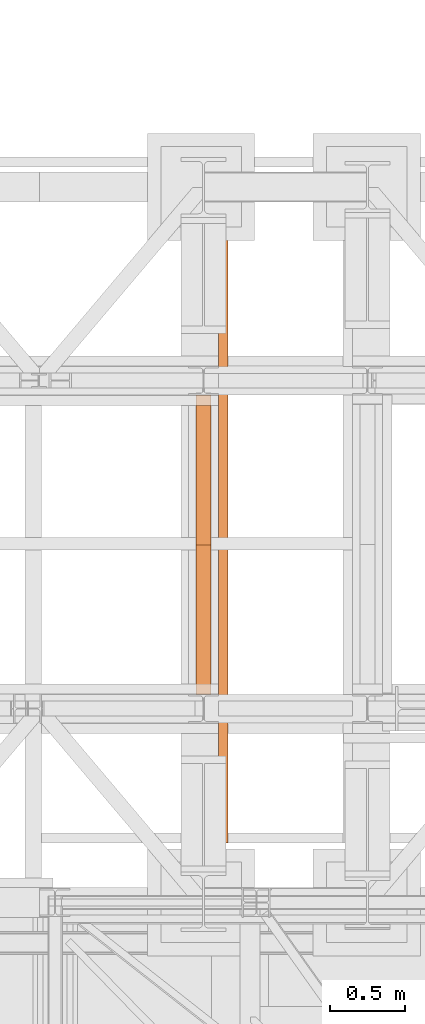
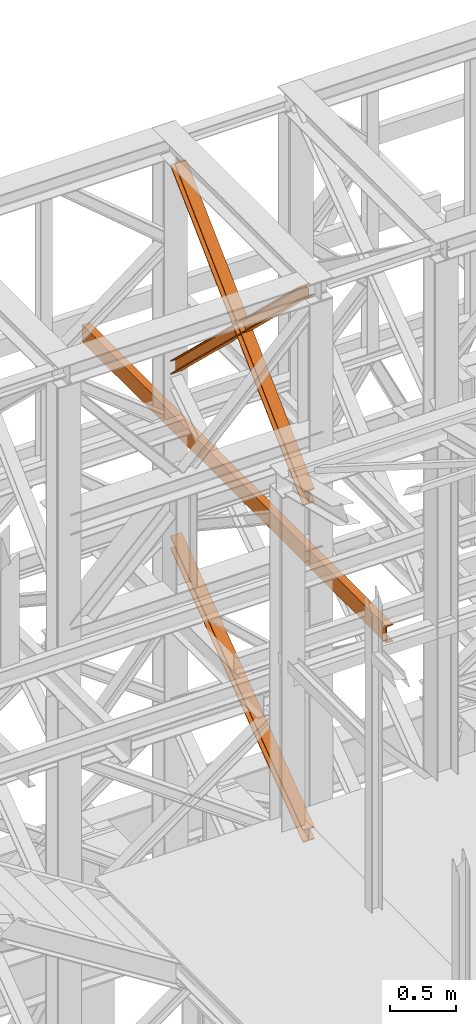
# One storey, part 123 of 208: 4 proxies.
"""IFC2X3 building model written with IfcOpenShell, lengths in millimetres."""

from ifc_helpers import new_model, entity, si_unit, converted_unit, frame, origin, origin_with_axes, place, context, subcontext, project, spatial, faceted_brep, element, save


model = new_model("IFC2X3")

# Units and contexts
model_context = context("Model", 3, precision=1e-05, world=origin())
plan_context = context("Plan", 3, precision=1e-05, world=origin())
body_context = subcontext(model_context, "Body", "Model", "MODEL_VIEW")
ifc_project = project(units=[si_unit("LENGTHUNIT", "METRE", prefix="MILLI"), converted_unit("PLANEANGLEUNIT", "DEGREE", entity("IfcPlaneAngleMeasure", 0.0174532925199433), si_unit("PLANEANGLEUNIT", "RADIAN"), dimensions=[0, 0, 0, 0, 0, 0, 0]), si_unit("AREAUNIT", "SQUARE_METRE"), si_unit("VOLUMEUNIT", "CUBIC_METRE")], contexts=[model_context, plan_context])

# Building, storey
building_placement = place(None, origin())
building = spatial("IfcBuilding", under=ifc_project, at=building_placement, CompositionType="COMPLEX")
storey_placement = place(building_placement, origin_with_axes())
storey = spatial("IfcBuildingStorey", under=building, at=storey_placement, Name="Geschoss", CompositionType="ELEMENT")

# Proxies
proxy_1_placement = place(storey_placement, frame((2142.895647595429, -15867.5743840594, 7147.394064575148), z_axis=(0.0, 0.0, 1.0), x_axis=(1.0, 0.0, 0.0)))
element("IfcBuildingElementProxy", 1, at=proxy_1_placement, inside=storey, context=body_context, shape_type="Brep", body=[
    faceted_brep([(100.0229386519513, 2010.009987483025, 1501.524522111415), (100.185572907496, 0.01000000000021828, 0.02100513656296243), (100.1844946360361, 0.01000000000021828, 9.82075546136366), (100.0218603804915, 2010.009987483025, 1511.324272436212), (0.02293925751655479, 2010.009987483025, 1501.513516974852), (0.185573513059353, 0.01000000000021828, 0.01000000000021828), (100.185572907496, 0.01000000000021828, 0.02100513656296243), (100.0229386519513, 2010.009987483025, 1501.524522111415), (0.02186098605488951, 2010.009987483025, 1511.313267299649), (0.1844952415995067, 0.01000000000021828, 9.809750324800916), (0.185573513059353, 0.01000000000021828, 0.01000000000021828), (0.02293925751655479, 2010.009987483025, 1501.513516974852), (47.52186069841264, 2010.009987483025, 1511.318494739518), (47.68449495395544, 0.01000000000021828, 9.814977764666764), (0.1844952415995067, 0.01000000000021828, 9.809750324800916), (0.02186098605488951, 2010.009987483025, 1511.313267299649), (47.51107798381418, 2010.009987483025, 1609.315997987507), (47.67371223936061, 0.01000000000021828, 107.8124810126556), (47.68449495395544, 0.01000000000021828, 9.814977764666764), (47.52186069841264, 2010.009987483025, 1511.318494739518), (0.01107827146006457, 2010.009987483025, 1609.310770547641), (0.1737125270028628, 0.01000000000021828, 107.8072535727861), (47.67371223936061, 0.01000000000021828, 107.8124810126556), (47.51107798381418, 2010.009987483025, 1609.315997987507), (0.01000000000021828, 2010.009987483025, 1619.110520872438), (0.1726342555448355, 0.01000000000021828, 117.6070038975868), (0.1737125270028628, 0.01000000000021828, 107.8072535727861), (0.01107827146006457, 2010.009987483025, 1609.310770547641), (100.009999394435, 2010.009987483025, 1619.121526009001), (100.1726336499778, 0.01000000000021828, 117.6180090341495), (0.1726342555448355, 0.01000000000021828, 117.6070038975868), (0.01000000000021828, 2010.009987483025, 1619.110520872438), (100.0110776658949, 2010.009987483025, 1609.321775684197), (100.1737119214376, 0.01000000000021828, 107.8182587093452), (100.1726336499778, 0.01000000000021828, 117.6180090341495), (100.009999394435, 2010.009987483025, 1619.121526009001), (52.5110779535371, 2010.009987483025, 1609.316548244331), (52.67371220908353, 0.01000000000021828, 107.8130312694793), (100.1737119214376, 0.01000000000021828, 107.8182587093452), (100.0110776658949, 2010.009987483025, 1609.321775684197), (52.52186066813374, 2010.009987483025, 1511.319044996339), (52.68449492368018, 0.01000000000021828, 9.815528021497812), (52.67371220908353, 0.01000000000021828, 107.8130312694793), (52.5110779535371, 2010.009987483025, 1609.316548244331), (100.0218603804915, 2010.009987483025, 1511.324272436212), (100.1844946360361, 0.01000000000021828, 9.82075546136366), (52.68449492368018, 0.01000000000021828, 9.815528021497812), (52.52186066813374, 2010.009987483025, 1511.319044996339), (100.185572907496, 0.01000000000021828, 0.02100513656296243), (0.185573513059353, 0.01000000000021828, 0.01000000000021828), (0.1844952415995067, 0.01000000000021828, 9.809750324800916), (47.68449495395544, 0.01000000000021828, 9.814977764666764), (47.67371223936061, 0.01000000000021828, 107.8124810126556), (0.1737125270028628, 0.01000000000021828, 107.8072535727861), (0.1726342555448355, 0.01000000000021828, 117.6070038975868), (100.1726336499778, 0.01000000000021828, 117.6180090341495), (100.1737119214376, 0.01000000000021828, 107.8182587093452), (52.67371220908353, 0.01000000000021828, 107.8130312694793), (52.68449492368018, 0.01000000000021828, 9.815528021497812), (100.1844946360361, 0.01000000000021828, 9.82075546136366), (100.0218603804915, 2010.009987483025, 1511.324272436212), (52.52186066813374, 2010.009987483025, 1511.319044996339), (52.5110779535371, 2010.009987483025, 1609.316548244331), (100.0110776658949, 2010.009987483025, 1609.321775684197), (100.009999394435, 2010.009987483025, 1619.121526009001), (0.01000000000021828, 2010.009987483025, 1619.110520872438), (0.01107827146006457, 2010.009987483025, 1609.310770547641), (47.51107798381418, 2010.009987483025, 1609.315997987507), (47.52186069841264, 2010.009987483025, 1511.318494739518), (0.02186098605488951, 2010.009987483025, 1511.313267299649), (0.02293925751655479, 2010.009987483025, 1501.513516974852), (100.0229386519513, 2010.009987483025, 1501.524522111415)], [[[0, 1, 2, 3]], [[4, 5, 6, 7]], [[8, 9, 10, 11]], [[12, 13, 14, 15]], [[16, 17, 18, 19]], [[20, 21, 22, 23]], [[24, 25, 26, 27]], [[28, 29, 30, 31]], [[32, 33, 34, 35]], [[36, 37, 38, 39]], [[40, 41, 42, 43]], [[44, 45, 46, 47]], [[48, 49, 50, 51, 52, 53, 54, 55, 56, 57, 58, 59]], [[60, 61, 62, 63, 64, 65, 66, 67, 68, 69, 70, 71]]], orient=[[False], [False], [False], [False], [False], [False], [False], [False], [False], [False], [False], [False], [False], [False]]),
])
proxy_2_placement = place(storey_placement, frame((2142.709266073973, -15867.57439014891, 10257.71351554296), z_axis=(0.0, 0.0, 1.0), x_axis=(1.0, 0.0, 0.0)))
element("IfcBuildingElementProxy", 2, at=proxy_2_placement, inside=storey, context=body_context, shape_type="Brep", body=[
    faceted_brep([(100.0212045496901, 2010.009993572538, 119.6472293306997), (100.1463438185765, 56.72628223557149, 1992.286543150845), (100.1466350609662, 68.07077152448983, 1992.286543150845), (100.0222231921616, 2010.009993572536, 130.5233411127829), (100.0222231921616, 2010.009993572536, 130.5233411127829), (100.1466350609662, 68.07077152448983, 1992.286543150845), (0.1466348943758931, 68.08252523311057, 1992.286543150842), (0.02222377857833635, 2010.009993572536, 130.5346095510231), (0.02222377857833635, 2010.009993572536, 130.5346095510231), (0.1466348943758931, 68.08252523311057, 1992.286543150842), (0.1463436519825336, 56.73803594420861, 1992.286543150842), (0.02120513611225761, 2010.009993572536, 119.6584977689327), (0.02120513611225761, 2010.009993572536, 119.6584977689327), (0.1463436519825336, 56.73803594420861, 1992.286543150842), (47.64634373111403, 56.73245293260334, 1992.286543150845), (47.52120485756132, 2010.009993572536, 119.6531452607651), (47.52120485756132, 2010.009993572536, 119.6531452607651), (47.64634373111403, 56.73245293260334, 1992.286543150845), (47.64488761591929, 0.01000608951108006, 1992.286543150845), (47.63979748861675, 0.01000608951108006, 1937.905972056111), (47.51101837541864, 2010.009993572536, 10.89202766673589), (47.51101837541864, 2010.009993572536, 10.89202766673589), (47.63979748861675, 0.01000608951108006, 1937.905972056111), (0.1397977671695116, 0.01000608951108006, 1937.911324564264), (0.011018653971405, 2010.009993572536, 10.89738017488162), (0.011018653971405, 2010.009993572536, 10.89738017488162), (0.1397977671695116, 0.01000608951108006, 1937.911324564264), (0.138779739916572, 0.01000608951108006, 1927.035210352397), (0.01000000000021828, 2010.009993572536, 0.02126843821861257), (0.01000000000021828, 2010.009993572536, 0.02126843821861257), (0.138779739916572, 0.01000608951108006, 1927.035210352397), (100.1387791534962, 0.01000608951108006, 1927.023941914182), (100.0099994135762, 2010.009993572536, 0.01000000000021828), (100.0099994135762, 2010.009993572536, 0.01000000000021828), (100.1387791534962, 0.01000608951108006, 1927.023941914182), (100.1397971807455, 0.01000608951108006, 1937.900056126053), (100.0110180675511, 2010.009993572536, 10.88611173667414), (100.0110180675511, 2010.009993572536, 10.88611173667414), (100.1397971807455, 0.01000608951108006, 1937.900056126053), (52.63979745929828, 0.01000608951108006, 1937.905408634202), (52.51101834609835, 2010.009993572536, 10.89146424482351), (52.51101834609835, 2010.009993572536, 10.89146424482351), (52.63979745929828, 0.01000608951108006, 1937.905408634202), (52.64488763917871, 0.01000000000021828, 1992.286543150845), (52.64634373944318, 56.73186524717494, 1992.286543150845), (52.52120482823921, 2010.009993572536, 119.65258183886), (52.52120482823921, 2010.009993572536, 119.65258183886), (52.64634373944318, 56.73186524717494, 1992.286543150845), (100.1463438185765, 56.72628223557149, 1992.286543150845), (100.0212045496901, 2010.009993572538, 119.6472293306997), (100.1463438185765, 56.72628223557149, 1992.286543150845), (52.64634373944318, 56.73186524717494, 1992.286543150845), (52.64488763917871, 0.01000000000021828, 1992.286543150845), (47.64488761591929, 0.01000608951108006, 1992.286543150845), (47.64634373111403, 56.73245293260334, 1992.286543150845), (0.1463436519825336, 56.73803594420861, 1992.286543150842), (0.1466348943758931, 68.08252523311057, 1992.286543150842), (100.1466350609662, 68.07077152448983, 1992.286543150845), (47.64488761591929, 0.01000608951108006, 1992.286543150845), (52.64488763917871, 0.01000000000021828, 1992.286543150845), (52.63979745929828, 0.01000608951108006, 1937.905408634202), (100.1397971807455, 0.01000608951108006, 1937.900056126053), (100.1387791534962, 0.01000608951108006, 1927.023941914182), (0.138779739916572, 0.01000608951108006, 1927.035210352397), (0.1397977671695116, 0.01000608951108006, 1937.911324564264), (47.63979748861675, 0.01000608951108006, 1937.905972056111), (100.0222231921616, 2010.009993572536, 130.5233411127829), (0.02222377857833635, 2010.009993572536, 130.5346095510231), (0.02120513611225761, 2010.009993572536, 119.6584977689327), (47.52120485756132, 2010.009993572536, 119.6531452607651), (47.51101837541864, 2010.009993572536, 10.89202766673589), (0.011018653971405, 2010.009993572536, 10.89738017488162), (0.01000000000021828, 2010.009993572536, 0.02126843821861257), (100.0099994135762, 2010.009993572536, 0.01000000000021828), (100.0110180675511, 2010.009993572536, 10.88611173667414), (52.51101834609835, 2010.009993572536, 10.89146424482351), (52.52120482823921, 2010.009993572536, 119.65258183886), (100.0212045496901, 2010.009993572538, 119.6472293306997)], [[[0, 1, 2, 3]], [[4, 5, 6, 7]], [[8, 9, 10, 11]], [[12, 13, 14, 15]], [[16, 17, 18, 19, 20]], [[21, 22, 23, 24]], [[25, 26, 27, 28]], [[29, 30, 31, 32]], [[33, 34, 35, 36]], [[37, 38, 39, 40]], [[41, 42, 43, 44, 45]], [[46, 47, 48, 49]], [[50, 51, 52, 53, 54, 55, 56, 57]], [[58, 59, 60, 61, 62, 63, 64, 65]], [[66, 67, 68, 69, 70, 71, 72, 73, 74, 75, 76, 77]]], orient=[[False], [False], [False], [False], [False], [False], [False], [False], [False], [False], [False], [False], [False], [False], [False]]),
])
proxy_3_placement = place(storey_placement, frame((2142.729037453721, -15867.5743840594, 10261.20680675583), z_axis=(0.0, 0.0, 1.0), x_axis=(1.0, 0.0, 0.0)))
element("IfcBuildingElementProxy", 3, at=proxy_3_placement, inside=storey, context=body_context, shape_type="Brep", body=[
    faceted_brep([(100.0219376352106, 0.01000000000021828, 130.5376928144524), (100.1248673996142, 1937.888230286315, 1988.793251937981), (100.1244756427459, 1949.231612164787, 1988.793251937985), (100.0209427866557, 0.01000000000021828, 119.6603850577285), (0.02193825012000161, 0.01000000000021828, 130.5496157990219), (0.1248673541031167, 1937.875796424816, 1988.793251937981), (100.1248673996142, 1937.888230286315, 1988.793251937981), (100.0219376352106, 0.01000000000021828, 130.5376928144524), (0.02094340156691033, 0.01000000000021828, 119.6723080422798), (0.1244755972311396, 1949.21917830328, 1988.793251937981), (0.1248673541031167, 1937.875796424816, 1988.793251937981), (0.02193825012000161, 0.01000000000021828, 130.5496157990219), (47.52094310948451, 0.01000000000021828, 119.6666446246109), (47.62447561884983, 1949.225084387492, 1988.793251937981), (0.1244755972311396, 1949.21917830328, 1988.793251937981), (0.02094340156691033, 0.01000000000021828, 119.6723080422798), (47.51099456772136, 0.01000000000021828, 10.89356727918312), (47.61776178021319, 2010.009987483025, 1938.307550640491), (47.62237652174554, 2010.009987483025, 1988.793251937981), (47.62447561884983, 1949.225084387492, 1988.793251937981), (47.52094310948451, 0.01000000000021828, 119.6666446246109), (0.01099485980739701, 0.01000000000021828, 10.899230696823), (0.1177620722974098, 2010.009987483025, 1938.313214058149), (47.61776178021319, 2010.009987483025, 1938.307550640491), (47.51099456772136, 0.01000000000021828, 10.89356727918312), (0.01000000000021828, 0.01000000000021828, 0.02192298452973773), (0.1167678252622864, 2010.009987483025, 1927.43590392548), (0.1177620722974098, 2010.009987483025, 1938.313214058149), (0.01099485980739701, 0.01000000000021828, 10.899230696823), (100.0099993850836, 0.01000000000021828, 0.01000000000021828), (100.1167672103493, 2010.009987483025, 1927.42398094095), (0.1167678252622864, 2010.009987483025, 1927.43590392548), (0.01000000000021828, 0.01000000000021828, 0.02192298452973773), (100.0109942448944, 0.01000000000021828, 10.88730771230075), (100.117761457379, 2010.009987483025, 1938.301291073616), (100.1167672103493, 2010.009987483025, 1927.42398094095), (100.0099993850836, 0.01000000000021828, 0.01000000000021828), (52.51099453697134, 0.01000000000021828, 10.89297112994063), (52.61776174946681, 2010.009987483025, 1938.306954491263), (100.117761457379, 2010.009987483025, 1938.301291073616), (100.0109942448944, 0.01000000000021828, 10.88730771230075), (52.52094307873631, 0.01000000000021828, 119.6660484753793), (52.62447562112538, 1949.225706080566, 1988.793251937981), (52.62237654549062, 2010.009987483025, 1988.793251937981), (52.61776174946681, 2010.009987483025, 1938.306954491263), (52.51099453697134, 0.01000000000021828, 10.89297112994063), (100.0209427866557, 0.01000000000021828, 119.6603850577285), (100.1244756427459, 1949.231612164787, 1988.793251937985), (52.62447562112538, 1949.225706080566, 1988.793251937981), (52.52094307873631, 0.01000000000021828, 119.6660484753793), (100.1248673996142, 1937.888230286315, 1988.793251937981), (0.1248673541031167, 1937.875796424816, 1988.793251937981), (0.1244755972311396, 1949.21917830328, 1988.793251937981), (47.62447561884983, 1949.225084387492, 1988.793251937981), (47.62237652174554, 2010.009987483025, 1988.793251937981), (52.62237654549062, 2010.009987483025, 1988.793251937981), (52.62447562112538, 1949.225706080566, 1988.793251937981), (100.1244756427459, 1949.231612164787, 1988.793251937985), (47.62237652174554, 2010.009987483025, 1988.793251937981), (47.61776178021319, 2010.009987483025, 1938.307550640491), (0.1177620722974098, 2010.009987483025, 1938.313214058149), (0.1167678252622864, 2010.009987483025, 1927.43590392548), (100.1167672103493, 2010.009987483025, 1927.42398094095), (100.117761457379, 2010.009987483025, 1938.301291073616), (52.61776174946681, 2010.009987483025, 1938.306954491263), (52.62237654549062, 2010.009987483025, 1988.793251937981), (100.0209427866557, 0.01000000000021828, 119.6603850577285), (52.52094307873631, 0.01000000000021828, 119.6660484753793), (52.51099453697134, 0.01000000000021828, 10.89297112994063), (100.0109942448944, 0.01000000000021828, 10.88730771230075), (100.0099993850836, 0.01000000000021828, 0.01000000000021828), (0.01000000000021828, 0.01000000000021828, 0.02192298452973773), (0.01099485980739701, 0.01000000000021828, 10.899230696823), (47.51099456772136, 0.01000000000021828, 10.89356727918312), (47.52094310948451, 0.01000000000021828, 119.6666446246109), (0.02094340156691033, 0.01000000000021828, 119.6723080422798), (0.02193825012000161, 0.01000000000021828, 130.5496157990219), (100.0219376352106, 0.01000000000021828, 130.5376928144524)], [[[0, 1, 2, 3]], [[4, 5, 6, 7]], [[8, 9, 10, 11]], [[12, 13, 14, 15]], [[16, 17, 18, 19, 20]], [[21, 22, 23, 24]], [[25, 26, 27, 28]], [[29, 30, 31, 32]], [[33, 34, 35, 36]], [[37, 38, 39, 40]], [[41, 42, 43, 44, 45]], [[46, 47, 48, 49]], [[50, 51, 52, 53, 54, 55, 56, 57]], [[58, 59, 60, 61, 62, 63, 64, 65]], [[66, 67, 68, 69, 70, 71, 72, 73, 74, 75, 76, 77]]], orient=[[False], [False], [False], [False], [False], [False], [False], [False], [False], [False], [False], [False], [False], [False], [False]]),
])
proxy_4_placement = place(storey_placement, frame((2293.254970018797, -16862.574391808, 9539.99), z_axis=(0.0, 0.0, 1.0), x_axis=(1.0, 0.0, 0.0)))
element("IfcBuildingElementProxy", 4, at=proxy_4_placement, inside=storey, context=body_context, shape_type="Brep", body=[
    faceted_brep([(65.01000000000204, 4599.878890000196, 0.01000000000021828), (65.01000000000022, 0.01000000000203727, 0.01000000000021828), (65.01000000000022, 0.01000000000203727, 3.132428070246533), (65.01000000000204, 4599.878890000196, 3.132428070246533), (65.01000000000204, 4599.878890000196, 3.132428070246533), (65.01000000000022, 0.01000000000203727, 3.132428070246533), (64.76726342282655, 0.01000000000203727, 4.748288908171162), (64.76726342282836, 4599.878890000196, 4.748288908171162), (64.76726342282836, 4599.878890000196, 4.748288908171162), (64.76726342282655, 0.01000000000203727, 4.748288908171162), (64.06053228585643, 0.01000000000203727, 6.221534443444398), (64.06053228585824, 4599.878890000196, 6.221534443444398), (64.06053228585824, 4599.878890000196, 6.221534443444398), (64.06053228585643, 0.01000000000203727, 6.221534443444398), (62.95215163846933, 0.01000000000203727, 7.422126703873801), (62.95215163847115, 4599.878890000196, 7.422126703873801), (62.95215163847115, 4599.878890000196, 7.422126703873801), (62.95215163846933, 0.01000000000203727, 7.422126703873801), (61.53995641148504, 0.01000000000203727, 8.244091391710754), (61.53995641148686, 4599.878890000196, 8.244091391710754), (61.53995641148686, 4599.878890000196, 8.244091391710754), (61.53995641148504, 0.01000000000203727, 8.244091391710754), (59.9485987225562, 0.01000000000203727, 8.614912102195376), (59.94859872255802, 4599.878890000196, 8.614912102195376), (59.94859872255802, 4599.878890000196, 8.614912102195376), (59.9485987225562, 0.01000000000203727, 8.614912102195376), (17.17267516602988, 0.01000000000203727, 12.0369859867169), (17.1726751660317, 4599.878890000196, 12.0369859867169), (17.1726751660317, 4599.878890000196, 12.0369859867169), (17.17267516602988, 0.01000000000203727, 12.0369859867169), (14.13462866898408, 0.01000000000203727, 12.74491643400506), (14.1346286689859, 4599.878890000196, 12.74491643400506), (14.1346286689859, 4599.878890000196, 12.74491643400506), (14.13462866898408, 0.01000000000203727, 12.74491643400506), (11.43861959928654, 0.01000000000203727, 14.31412174714933), (11.43861959928836, 4599.878890000196, 14.31412174714933), (11.43861959928836, 4599.878890000196, 14.31412174714933), (11.43861959928654, 0.01000000000203727, 14.31412174714933), (9.32262018154779, 0.01000000000203727, 16.60616151705835), (9.32262018154961, 4599.878890000196, 16.60616151705835), (9.32262018154961, 4599.878890000196, 16.60616151705835), (9.32262018154779, 0.01000000000203727, 16.60616151705835), (7.97340619278566, 0.01000000000203727, 19.41872117530875), (7.973406192787479, 4599.878890000196, 19.41872117530875), (7.973406192787479, 4599.878890000196, 19.41872117530875), (7.97340619278566, 0.01000000000203727, 19.41872117530875), (7.510000000000218, 0.01000000000203727, 22.50354641134618), (7.510000000002037, 4599.878890000196, 22.50354641134618), (7.510000000002037, 4599.878890000196, 22.50354641134618), (7.510000000000218, 0.01000000000203727, 22.50354641134618), (7.510000000000218, 0.01000000000203727, 137.5164535886524), (7.510000000002037, 4599.878890000196, 137.5164535886524), (7.510000000002037, 4599.878890000196, 137.5164535886524), (7.510000000000218, 0.01000000000203727, 137.5164535886524), (7.97340619278566, 0.01000000000203727, 140.6012788246917), (7.973406192787479, 4599.878890000196, 140.6012788246917), (7.973406192787479, 4599.878890000196, 140.6012788246917), (7.97340619278566, 0.01000000000203727, 140.6012788246917), (9.32262018154779, 0.01000000000203727, 143.4138384829403), (9.32262018154961, 4599.878890000196, 143.4138384829403), (9.32262018154961, 4599.878890000196, 143.4138384829403), (9.32262018154779, 0.01000000000203727, 143.4138384829403), (11.43861959928654, 0.01000000000203727, 145.7058782528493), (11.43861959928836, 4599.878890000196, 145.7058782528493), (11.43861959928836, 4599.878890000196, 145.7058782528493), (11.43861959928654, 0.01000000000203727, 145.7058782528493), (14.13462866898408, 0.01000000000203727, 147.2750835659936), (14.1346286689859, 4599.878890000196, 147.2750835659936), (14.1346286689859, 4599.878890000196, 147.2750835659936), (14.13462866898408, 0.01000000000203727, 147.2750835659936), (17.17267516602988, 0.01000000000203727, 147.9830140132817), (17.1726751660317, 4599.878890000196, 147.9830140132817), (17.1726751660317, 4599.878890000196, 147.9830140132817), (17.17267516602988, 0.01000000000203727, 147.9830140132817), (59.9485987225562, 0.01000000000203727, 151.4050878978032), (59.94859872255802, 4599.878890000196, 151.4050878978032), (59.94859872255802, 4599.878890000196, 151.4050878978032), (59.9485987225562, 0.01000000000203727, 151.4050878978032), (61.53995641148504, 0.01000000000203727, 151.7759086082879), (61.53995641148686, 4599.878890000196, 151.7759086082879), (61.53995641148686, 4599.878890000196, 151.7759086082879), (61.53995641148504, 0.01000000000203727, 151.7759086082879), (62.95215163846933, 0.01000000000203727, 152.5978732961248), (62.95215163847115, 4599.878890000196, 152.5978732961248), (62.95215163847115, 4599.878890000196, 152.5978732961248), (62.95215163846933, 0.01000000000203727, 152.5978732961248), (64.06053228585643, 0.01000000000203727, 153.7984655565542), (64.06053228585824, 4599.878890000196, 153.7984655565542), (64.06053228585824, 4599.878890000196, 153.7984655565542), (64.06053228585643, 0.01000000000203727, 153.7984655565542), (64.76726342282655, 0.01000000000203727, 155.2717110918275), (64.76726342282836, 4599.878890000196, 155.2717110918275), (64.76726342282836, 4599.878890000196, 155.2717110918275), (64.76726342282655, 0.01000000000203727, 155.2717110918275), (65.01000000000022, 0.01000000000203727, 156.8875719297521), (65.01000000000204, 4599.878890000196, 156.8875719297521), (65.01000000000204, 4599.878890000196, 156.8875719297521), (65.01000000000022, 0.01000000000203727, 156.8875719297521), (65.01000000000022, 0.01000000000203727, 160.0100000000002), (65.01000000000204, 4599.878890000196, 160.0100000000002), (65.01000000000204, 4599.878890000196, 160.0100000000002), (65.01000000000022, 0.01000000000203727, 160.0100000000002), (0.01000000000021828, 0.01000000000203727, 160.0100000000002), (0.01000000000203727, 4599.878890000196, 160.0100000000002), (0.01000000000203727, 4599.878890000196, 160.0100000000002), (0.01000000000021828, 0.01000000000203727, 160.0100000000002), (0.01000000000021828, 0.01000000000203727, 0.01000000000021828), (0.01000000000203727, 4599.878890000196, 0.01000000000021828), (0.01000000000203727, 4599.878890000196, 0.01000000000021828), (0.01000000000021828, 0.01000000000203727, 0.01000000000021828), (65.01000000000022, 0.01000000000203727, 0.01000000000021828), (65.01000000000204, 4599.878890000196, 0.01000000000021828), (65.01000000000204, 4599.878890000196, 0.01000000000021828), (65.01000000000204, 4599.878890000196, 3.132428070246533), (64.76726342282836, 4599.878890000196, 4.748288908171162), (64.06053228585824, 4599.878890000196, 6.221534443444398), (62.95215163847115, 4599.878890000196, 7.422126703873801), (61.53995641148686, 4599.878890000196, 8.244091391710754), (59.94859872255802, 4599.878890000196, 8.614912102195376), (17.1726751660317, 4599.878890000196, 12.0369859867169), (14.1346286689859, 4599.878890000196, 12.74491643400506), (11.43861959928836, 4599.878890000196, 14.31412174714933), (9.32262018154961, 4599.878890000196, 16.60616151705835), (7.973406192787479, 4599.878890000196, 19.41872117530875), (7.510000000002037, 4599.878890000196, 22.50354641134618), (7.510000000002037, 4599.878890000196, 137.5164535886524), (7.973406192787479, 4599.878890000196, 140.6012788246917), (9.32262018154961, 4599.878890000196, 143.4138384829403), (11.43861959928836, 4599.878890000196, 145.7058782528493), (14.1346286689859, 4599.878890000196, 147.2750835659936), (17.1726751660317, 4599.878890000196, 147.9830140132817), (59.94859872255802, 4599.878890000196, 151.4050878978032), (61.53995641148686, 4599.878890000196, 151.7759086082879), (62.95215163847115, 4599.878890000196, 152.5978732961248), (64.06053228585824, 4599.878890000196, 153.7984655565542), (64.76726342282836, 4599.878890000196, 155.2717110918275), (65.01000000000204, 4599.878890000196, 156.8875719297521), (65.01000000000204, 4599.878890000196, 160.0100000000002), (0.01000000000203727, 4599.878890000196, 160.0100000000002), (0.01000000000203727, 4599.878890000196, 0.01000000000021828), (65.01000000000022, 0.01000000000203727, 0.01000000000021828), (0.01000000000021828, 0.01000000000203727, 0.01000000000021828), (0.01000000000021828, 0.01000000000203727, 160.0100000000002), (65.01000000000022, 0.01000000000203727, 160.0100000000002), (65.01000000000022, 0.01000000000203727, 156.8875719297521), (64.76726342282655, 0.01000000000203727, 155.2717110918275), (64.06053228585643, 0.01000000000203727, 153.7984655565542), (62.95215163846933, 0.01000000000203727, 152.5978732961248), (61.53995641148504, 0.01000000000203727, 151.7759086082879), (59.9485987225562, 0.01000000000203727, 151.4050878978032), (17.17267516602988, 0.01000000000203727, 147.9830140132817), (14.13462866898408, 0.01000000000203727, 147.2750835659936), (11.43861959928654, 0.01000000000203727, 145.7058782528493), (9.32262018154779, 0.01000000000203727, 143.4138384829403), (7.97340619278566, 0.01000000000203727, 140.6012788246917), (7.510000000000218, 0.01000000000203727, 137.5164535886524), (7.510000000000218, 0.01000000000203727, 22.50354641134618), (7.97340619278566, 0.01000000000203727, 19.41872117530875), (9.32262018154779, 0.01000000000203727, 16.60616151705835), (11.43861959928654, 0.01000000000203727, 14.31412174714933), (14.13462866898408, 0.01000000000203727, 12.74491643400506), (17.17267516602988, 0.01000000000203727, 12.0369859867169), (59.9485987225562, 0.01000000000203727, 8.614912102195376), (61.53995641148504, 0.01000000000203727, 8.244091391710754), (62.95215163846933, 0.01000000000203727, 7.422126703873801), (64.06053228585643, 0.01000000000203727, 6.221534443444398), (64.76726342282655, 0.01000000000203727, 4.748288908171162), (65.01000000000022, 0.01000000000203727, 3.132428070246533)], [[[0, 1, 2, 3]], [[4, 5, 6, 7]], [[8, 9, 10, 11]], [[12, 13, 14, 15]], [[16, 17, 18, 19]], [[20, 21, 22, 23]], [[24, 25, 26, 27]], [[28, 29, 30, 31]], [[32, 33, 34, 35]], [[36, 37, 38, 39]], [[40, 41, 42, 43]], [[44, 45, 46, 47]], [[48, 49, 50, 51]], [[52, 53, 54, 55]], [[56, 57, 58, 59]], [[60, 61, 62, 63]], [[64, 65, 66, 67]], [[68, 69, 70, 71]], [[72, 73, 74, 75]], [[76, 77, 78, 79]], [[80, 81, 82, 83]], [[84, 85, 86, 87]], [[88, 89, 90, 91]], [[92, 93, 94, 95]], [[96, 97, 98, 99]], [[100, 101, 102, 103]], [[104, 105, 106, 107]], [[108, 109, 110, 111]], [[112, 113, 114, 115, 116, 117, 118, 119, 120, 121, 122, 123, 124, 125, 126, 127, 128, 129, 130, 131, 132, 133, 134, 135, 136, 137, 138, 139]], [[140, 141, 142, 143, 144, 145, 146, 147, 148, 149, 150, 151, 152, 153, 154, 155, 156, 157, 158, 159, 160, 161, 162, 163, 164, 165, 166, 167]]], orient=[[False], [False], [False], [False], [False], [False], [False], [False], [False], [False], [False], [False], [False], [False], [False], [False], [False], [False], [False], [False], [False], [False], [False], [False], [False], [False], [False], [False], [False], [False]]),
])

save(model, "model.ifc")
